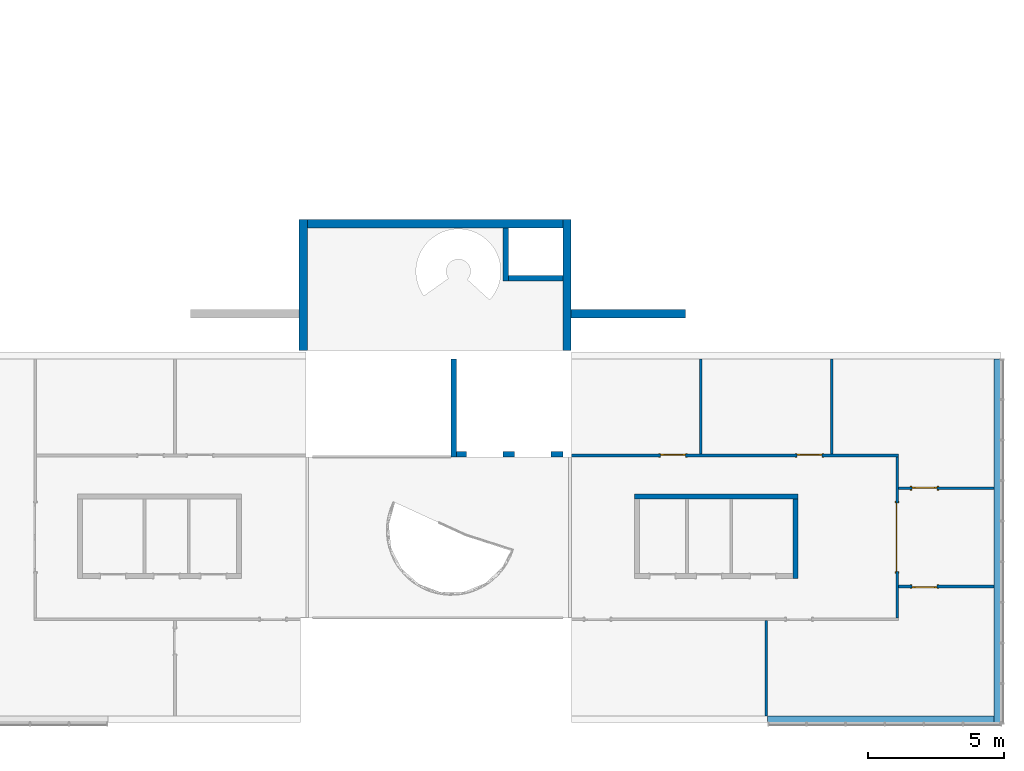
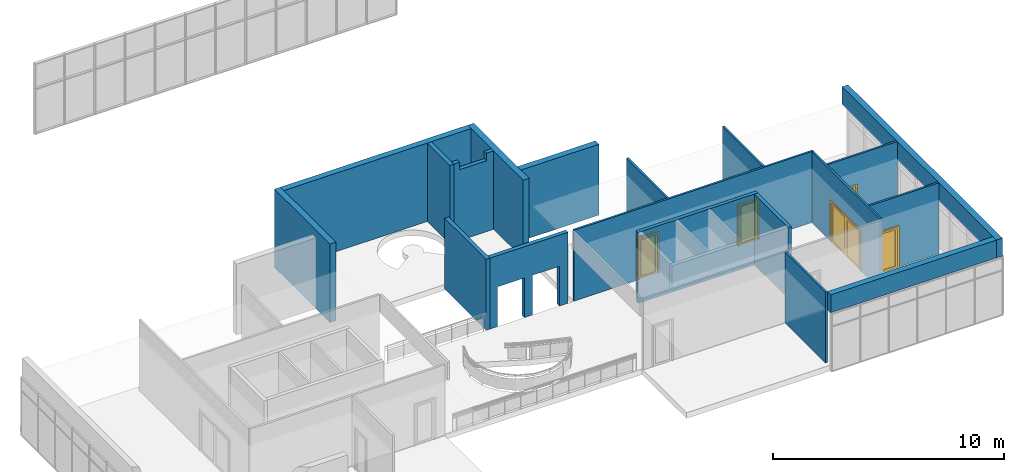
# One storey, part 9 of 11: 19 walls, 5 doors, 8 openings.
"""IFC2X3 building model written with IfcOpenShell, lengths in millimetres."""

from ifc_helpers import new_model, entity, si_unit, converted_unit, direction, frame, frame_2d, origin, origin_2d_with_axis, place, context, subcontext, project, spatial, polyline, rectangle, outline, extrude, source, transform, mapped, material, material_list, layer, layer_set, layer_usage, type_object, type_shapes, element, fill, save


model = new_model("IFC2X3")

# Units and contexts
model_context = context("Model", 3, precision=1e-06, world=origin(), true_north=direction((2.0, 6.12303176911189e-17, 1.0)))
context_of_model = context(None, 3, precision=1e-06, world=origin(), true_north=direction((2.0, 6.12303176911189e-17, 1.0)))
body_context = subcontext(model_context, "Body", "Model", "MODEL_VIEW")
ifc_project = project(units=[si_unit("LENGTHUNIT", "METRE", prefix="MILLI"), si_unit("AREAUNIT", "SQUARE_METRE", prefix="MILLI"), si_unit("VOLUMEUNIT", "CUBIC_METRE", prefix="MILLI"), converted_unit("PLANEANGLEUNIT", "DEGREE", entity("IfcRatioMeasure", 0.0174532925199433), si_unit("PLANEANGLEUNIT", "RADIAN"), dimensions=[0, 0, 0, 0, 0, 0, 0]), si_unit("TIMEUNIT", "SECOND")], contexts=[model_context, context_of_model])

# Site, building, storey
site_placement = place(None, origin())
site = spatial("IfcSite", under=ifc_project, at=site_placement, CompositionType="ELEMENT")
building_placement = place(site_placement, origin())
building = spatial("IfcBuilding", under=site, at=building_placement, CompositionType="ELEMENT")
storey_placement = place(building_placement, frame((0.0, 0.0, 3750.0)))
storey = spatial("IfcBuildingStorey", under=building, at=storey_placement, Name="02. 2 etg.", CompositionType="ELEMENT", Elevation=3750.00000000068)

# Wall, opening, door
ifc_material_1 = material(Name="Steel, Paint Finish, Ivory, Matte")
ifc_layer_1 = layer(ifc_material_1, 100.0)
ifc_layer_set_1 = layer_set([ifc_layer_1], Name="Basic Wall:_100mm")
ifc_layer_usage_1 = layer_usage(ifc_layer_set_1, "AXIS2", "POSITIVE", -50.0)
wall_1_placement = place(storey_placement, frame((37258.2357123495, -9550.0, 0.0), z_axis=(0.0, 0.0, 1.0), x_axis=(0.0, 1.0, 0.0)))
wall_1 = element("IfcWallStandardCase", 1, at=wall_1_placement, inside=storey, material=ifc_layer_usage_1, Name="Basic Wall:_100mm", ObjectType="Basic Wall:_100mm", context=body_context, shape_type="SweptSolid", body=[
    extrude(rectangle(XDim=5900.0, YDim=100.000000000003, at=frame_2d((2950.0, 0.0), x_axis=(-1.0, 0.0))), origin(), (0.0, 0.0, 1.0), 3750.0),
])
opening_1_placement = place(wall_1_placement, frame((1700.0, -50.0, 0.0)))
opening_1 = element("IfcOpeningElement", 2, at=opening_1_placement, cuts=wall_1, Name="M_Double-Glass 1:2500x2100:2500x2100:1", ObjectType="Opening", context=body_context, shape_type="SweptSolid", body=[
    extrude(rectangle(XDim=2500.0, YDim=2100.0, at=frame_2d((1050.0, 1250.0), x_axis=(0.0, 1.0))), frame((0.0, 0.0, 0.0), z_axis=(0.0, 1.0, 0.0), x_axis=(0.0, 0.0, 1.0)), (0.0, 0.0, 1.0), 100.0),
])
ifc_material_2 = material(Name="Metal - Stainless Steel,Polished")
ifc_material_3 = material(Name="Glass")
ifc_material_4 = material(Name="Steel, Chrome Plated")
ifc_material_list_1 = material_list([ifc_material_2, ifc_material_3, ifc_material_4])
door_style_1 = type_object("IfcDoorStyle", Name="2500x2100", ConstructionType="NOTDEFINED", OperationType="DOUBLE_DOOR_SINGLE_SWING", ParameterTakesPrecedence=False, Sizeable=False)
shared_shape_1 = source(origin(), body_context, "Body", "SweptSolid", [
    extrude(outline(polyline([(-1326.0, -1069.0), (-1250.0, -1069.0), (-1250.0, 1031.0), (1250.0, 1031.0), (1250.0, -1069.0), (1326.0, -1069.0), (1326.0, 1107.0), (-1326.0, 1107.0), (-1326.0, -1069.0)])), frame((1250.0, -25.0, 1069.0), z_axis=(0.0, 1.0, 0.0), x_axis=(-1.0, 0.0, 0.0)), (0.0, 0.0, 1.0), 25.0),
    extrude(outline(polyline([(-1250.0, -1031.0), (-1250.0, 1069.0), (-1326.0, 1069.0), (-1326.0, -1107.0), (1326.0, -1107.0), (1326.0, 1069.0), (1250.0, 1069.0), (1250.0, -1031.0), (-1250.0, -1031.0)])), frame((1250.0, 100.0, 1069.0), z_axis=(0.0, -1.0, 0.0), x_axis=(-1.0, 0.0, 0.0)), (0.0, 0.0, -1.0), 24.999999999997),
    extrude(rectangle(XDim=7.14374999999973, YDim=1046.8, at=frame_2d((0.0, -5.6843418860808e-14), x_axis=(1.0, 0.0))), frame((1875.0, 78.1718749999958, 102.0), z_axis=(0.0, 0.0, 1.0), x_axis=(0.0, 1.0, 0.0)), (0.0, 0.0, 1.0), 1896.0),
    extrude(rectangle(XDim=7.14374999999973, YDim=1046.8, at=frame_2d((0.0, -5.6843418860808e-14), x_axis=(1.0, 0.0))), frame((625.0, 78.1718749999958, 102.0), z_axis=(0.0, 0.0, 1.0), x_axis=(0.0, 1.0, 0.0)), (0.0, 0.0, 1.0), 1896.0),
    extrude(outline(polyline([(-1050.0, -1250.0), (1050.0, -1250.0), (1050.0, 1250.0), (-1050.0, 1250.0), (-1050.0, -1250.0)]), holes=[polyline([(-948.0, 101.600000000038), (-948.0, 1148.40000000004), (948.0, 1148.40000000004), (948.0, 101.600000000038), (-948.0, 101.600000000038)]), polyline([(-948.0, -1148.39999999996), (-948.0, -101.599999999961), (948.0, -101.599999999961), (948.0, -1148.39999999996), (-948.0, -1148.39999999996)])]), frame((1250.0, 49.0, 1050.0), z_axis=(0.0, 1.0, 0.0), x_axis=(0.0, 0.0, -1.0)), (0.0, 0.0, 1.0), 51.0),
])
type_shapes(door_style_1, [shared_shape_1])
door_1_placement = place(opening_1_placement, origin())
door_1 = element("IfcDoor", 3, at=door_1_placement, inside=storey, type_object=door_style_1, material=ifc_material_list_1, Name="M_Double-Glass 1:2500x2100:2500x2100", ObjectType="2500x2100", OverallHeight=2100.0, OverallWidth=2500.0, context=body_context, shape_type="MappedRepresentation", body=[
    mapped(shared_shape_1, transform((0.0, 0.0, 0.0), scale=1.0)),
])
fill(opening_1, door_1)

# Wall
ifc_layer_usage_2 = layer_usage(ifc_layer_set_1, "AXIS2", "POSITIVE", -50.0)
wall_2_placement = place(storey_placement, frame((32458.2357123495, -13140.0, 0.0), z_axis=(0.0, 0.0, 1.0), x_axis=(0.0, 1.0, 0.0)))
element("IfcWallStandardCase", 4, at=wall_2_placement, inside=storey, material=ifc_layer_usage_2, Name="Basic Wall:_100mm", ObjectType="Basic Wall:_100mm", context=body_context, shape_type="SweptSolid", body=[
    extrude(rectangle(XDim=3490.00000000005, YDim=100.000000000003, at=frame_2d((1745.00000000002, 0.0), x_axis=(-1.0, 0.0))), origin(), (0.0, 0.0, 1.0), 3750.0),
])

# Wall, openings, doors
ifc_layer_usage_3 = layer_usage(ifc_layer_set_1, "AXIS2", "POSITIVE", -50.0)
wall_3_placement = place(storey_placement, frame((25318.2357123494, -3600.0, 0.0)))
wall_3 = element("IfcWallStandardCase", 5, at=wall_3_placement, inside=storey, material=ifc_layer_usage_3, Name="Basic Wall:_100mm", ObjectType="Basic Wall:_100mm", context=body_context, shape_type="SweptSolid", body=[
    extrude(rectangle(XDim=11990.0, YDim=100.0, at=frame_2d((5995.00000000001, 1.27897692436818e-13), x_axis=(-1.0, 0.0))), origin(), (0.0, 0.0, 1.0), 3750.0),
])
opening_2_placement = place(wall_3_placement, frame((8275.0, -50.0, 0.0)))
opening_2 = element("IfcOpeningElement", 6, at=opening_2_placement, cuts=wall_3, Name="M_Single-Glass 1:0915 x 2134mm:0915 x 2134mm:1", ObjectType="Opening", context=body_context, shape_type="SweptSolid", body=[
    extrude(rectangle(XDim=914.999999999999, YDim=2134.0, at=frame_2d((1067.0, 457.5), x_axis=(0.0, 1.0))), frame((0.0, 0.0, 0.0), z_axis=(0.0, 1.0, 0.0), x_axis=(0.0, 0.0, 1.0)), (0.0, 0.0, 1.0), 100.0),
])
opening_3_placement = place(wall_3_placement, frame((3275.0, -50.0, 0.0)))
opening_3 = element("IfcOpeningElement", 7, at=opening_3_placement, cuts=wall_3, Name="M_Single-Glass 1:0915 x 2134mm:0915 x 2134mm:1", ObjectType="Opening", context=body_context, shape_type="SweptSolid", body=[
    extrude(rectangle(XDim=914.999999999999, YDim=2134.0, at=frame_2d((1067.0, 457.5), x_axis=(0.0, 1.0))), frame((0.0, 0.0, 0.0), z_axis=(0.0, 1.0, 0.0), x_axis=(0.0, 0.0, 1.0)), (0.0, 0.0, 1.0), 100.0),
])
ifc_material_5 = material(Name="Stainless Steel")
ifc_material_list_2 = material_list([ifc_material_5, ifc_material_3])
door_style_2 = type_object("IfcDoorStyle", Name="0915 x 2134mm", ConstructionType="NOTDEFINED", OperationType="SINGLE_SWING_RIGHT", ParameterTakesPrecedence=False, Sizeable=False)
shared_shape_2 = source(origin(), body_context, "Body", "SweptSolid", [
    extrude(outline(polyline([(-457.500000000003, -1048.0), (-457.500000000003, 1086.0), (-533.499999999999, 1086.0), (-533.499999999999, -1124.0), (533.500000000001, -1124.0), (533.500000000001, 1086.0), (457.500000000001, 1086.0), (457.500000000001, -1048.0), (-457.500000000003, -1048.0)])), frame((457.500000000001, -25.0, 1086.0), z_axis=(0.0, -1.0, 0.0), x_axis=(-1.0, 0.0, 0.0)), (0.0, 0.0, -1.0), 25.0),
    extrude(outline(polyline([(-457.500000000001, -1048.0), (-457.500000000001, 1086.0), (-533.499999999997, 1086.0), (-533.499999999997, -1124.0), (533.499999999999, -1124.0), (533.499999999999, 1086.0), (457.499999999999, 1086.0), (457.499999999999, -1048.0), (-457.500000000001, -1048.0)])), frame((457.499999999999, 100.0, 1086.0), z_axis=(0.0, -1.0, 0.0), x_axis=(-1.0, 0.0, 0.0)), (0.0, 0.0, -1.0), 25.0000000000156),
    extrude(rectangle(XDim=6.35, YDim=711.0, at=frame_2d((-4.21884749357559e-15, 0.0), x_axis=(1.0, 0.0))), frame((457.5, 74.6000000000039, 102.0), z_axis=(0.0, 0.0, 1.0), x_axis=(0.0, 1.0, 0.0)), (0.0, 0.0, 1.0), 1930.0),
    extrude(outline(polyline([(-1067.0, -457.499999999998), (1067.0, -457.499999999998), (1067.0, 457.499999999998), (-1067.0, 457.499999999998), (-1067.0, -457.499999999998)]), holes=[polyline([(-965.0, 355.499999999998), (965.0, 355.499999999998), (965.0, -355.500000000002), (-965.0, -355.500000000002), (-965.0, 355.499999999998)])]), frame((457.499999999998, 49.0, 1067.0), z_axis=(0.0, 1.0, 0.0), x_axis=(0.0, 0.0, -1.0)), (0.0, 0.0, 1.0), 51.0),
])
type_shapes(door_style_2, [shared_shape_2])
door_2_placement = place(opening_2_placement, origin())
door_2 = element("IfcDoor", 8, at=door_2_placement, inside=storey, type_object=door_style_2, material=ifc_material_list_2, Name="M_Single-Glass 1:0915 x 2134mm:0915 x 2134mm", ObjectType="0915 x 2134mm", OverallHeight=2134.0, OverallWidth=915.0, context=body_context, shape_type="MappedRepresentation", body=[
    mapped(shared_shape_2, transform((0.0, 0.0, 0.0), scale=1.0)),
])
fill(opening_2, door_2)
ifc_material_list_3 = material_list([ifc_material_5, ifc_material_3])
door_3_placement = place(opening_3_placement, origin())
door_3 = element("IfcDoor", 9, at=door_3_placement, inside=storey, type_object=door_style_2, material=ifc_material_list_3, Name="M_Single-Glass 1:0915 x 2134mm:0915 x 2134mm", ObjectType="0915 x 2134mm", OverallHeight=2134.0, OverallWidth=915.0, context=body_context, shape_type="MappedRepresentation", body=[
    mapped(shared_shape_2, transform((0.0, 0.0, 0.0), scale=1.0)),
])
fill(opening_3, door_3)

# Wall, opening, door
ifc_layer_usage_4 = layer_usage(ifc_layer_set_1, "AXIS2", "POSITIVE", -50.0)
wall_4_placement = place(storey_placement, frame((37308.2357123495, -4800.0, 0.0)))
wall_4 = element("IfcWallStandardCase", 10, at=wall_4_placement, inside=storey, material=ifc_layer_usage_4, Name="Basic Wall:_100mm", ObjectType="Basic Wall:_100mm", context=body_context, shape_type="SweptSolid", body=[
    extrude(rectangle(XDim=3490.00000000001, YDim=100.0, at=frame_2d((1745.0, 0.0), x_axis=(-1.0, 0.0))), origin(), (0.0, 0.0, 1.0), 3750.0),
])
opening_4_placement = place(wall_4_placement, frame((500.0, -50.0, 0.0)))
opening_4 = element("IfcOpeningElement", 11, at=opening_4_placement, cuts=wall_4, Name="M_Single-Glass 1:0915 x 2134mm:0915 x 2134mm:1", ObjectType="Opening", context=body_context, shape_type="SweptSolid", body=[
    extrude(rectangle(XDim=914.999999999999, YDim=2134.0, at=frame_2d((1067.0, 457.5), x_axis=(0.0, -1.0))), frame((0.0, 0.0, 0.0), z_axis=(0.0, 1.0, 0.0), x_axis=(0.0, 0.0, 1.0)), (0.0, 0.0, 1.0), 100.0),
])
ifc_material_list_4 = material_list([ifc_material_5, ifc_material_3])
door_style_3 = type_object("IfcDoorStyle", Name="0915 x 2134mm", ConstructionType="NOTDEFINED", OperationType="SINGLE_SWING_LEFT", ParameterTakesPrecedence=False, Sizeable=False)
shared_shape_3 = source(origin(), body_context, "Body", "SweptSolid", [
    extrude(outline(polyline([(-457.500000000003, -1048.0), (-457.500000000003, 1086.0), (-533.499999999999, 1086.0), (-533.499999999999, -1124.0), (533.500000000001, -1124.0), (533.500000000001, 1086.0), (457.500000000001, 1086.0), (457.500000000001, -1048.0), (-457.500000000003, -1048.0)])), frame((457.499999999999, 0.0, 1086.0), z_axis=(0.0, 1.0, 0.0), x_axis=(1.0, 0.0, 0.0)), (0.0, 0.0, -1.0), 25.0),
    extrude(outline(polyline([(-457.500000000001, -1048.0), (-457.500000000001, 1086.0), (-533.499999999997, 1086.0), (-533.499999999997, -1124.0), (533.499999999999, -1124.0), (533.499999999999, 1086.0), (457.499999999999, 1086.0), (457.499999999999, -1048.0), (-457.500000000001, -1048.0)])), frame((457.500000000001, 125.0, 1086.0), z_axis=(0.0, 1.0, 0.0), x_axis=(1.0, 0.0, 0.0)), (0.0, 0.0, -1.0), 25.0000000000156),
    extrude(rectangle(XDim=711.0, YDim=6.35, at=origin_2d_with_axis()), frame((457.5, 74.6000000000257, 102.0)), (0.0, 0.0, 1.0), 1930.0),
    extrude(outline(polyline([(-1067.0, -457.499999999998), (1067.0, -457.499999999998), (1067.0, 457.499999999998), (-1067.0, 457.499999999998), (-1067.0, -457.499999999998)]), holes=[polyline([(-965.0, 355.499999999998), (965.0, 355.499999999998), (965.0, -355.500000000002), (-965.0, -355.500000000002), (-965.0, 355.499999999998)])]), frame((457.500000000002, 100.0, 1067.0), z_axis=(0.0, -1.0, 0.0), x_axis=(0.0, 0.0, -1.0)), (0.0, 0.0, 1.0), 51.0),
])
type_shapes(door_style_3, [shared_shape_3])
door_4_placement = place(opening_4_placement, origin())
door_4 = element("IfcDoor", 12, at=door_4_placement, inside=storey, type_object=door_style_3, material=ifc_material_list_4, Name="M_Single-Glass 1:0915 x 2134mm:0915 x 2134mm", ObjectType="0915 x 2134mm", OverallHeight=2134.0, OverallWidth=915.0, context=body_context, shape_type="MappedRepresentation", body=[
    mapped(shared_shape_3, transform((0.0, 0.0, 0.0), scale=1.0)),
])
fill(opening_4, door_4)

ifc_layer_usage_5 = layer_usage(ifc_layer_set_1, "AXIS2", "POSITIVE", -50.0)
wall_5_placement = place(storey_placement, frame((37308.2357123495, -8400.0, 0.0)))
wall_5 = element("IfcWallStandardCase", 13, at=wall_5_placement, inside=storey, material=ifc_layer_usage_5, Name="Basic Wall:_100mm", ObjectType="Basic Wall:_100mm", context=body_context, shape_type="SweptSolid", body=[
    extrude(rectangle(XDim=3490.00000000002, YDim=99.9999999999989, at=frame_2d((1745.00000000001, 0.0), x_axis=(-1.0, 0.0))), origin(), (0.0, 0.0, 1.0), 3750.0),
])
opening_5_placement = place(wall_5_placement, frame((1415.0, 50.0, 0.0)))
opening_5 = element("IfcOpeningElement", 14, at=opening_5_placement, cuts=wall_5, Name="M_Single-Glass 1:0915 x 2134mm:0915 x 2134mm:1", ObjectType="Opening", context=body_context, shape_type="SweptSolid", body=[
    extrude(rectangle(XDim=914.999999999999, YDim=2134.0, at=frame_2d((1067.0, 457.5), x_axis=(0.0, 1.0))), frame((0.0, 0.0, 0.0), z_axis=(0.0, -1.0, 0.0), x_axis=(0.0, 0.0, 1.0)), (0.0, 0.0, 1.0), 100.0),
])
ifc_material_list_5 = material_list([ifc_material_5, ifc_material_3])
door_5_placement = place(opening_5_placement, frame((0.0, 0.0, 0.0), z_axis=(0.0, 0.0, 1.0), x_axis=(-1.0, 0.0, 0.0)))
door_5 = element("IfcDoor", 15, at=door_5_placement, inside=storey, type_object=door_style_2, material=ifc_material_list_5, Name="M_Single-Glass 1:0915 x 2134mm:0915 x 2134mm", ObjectType="0915 x 2134mm", OverallHeight=2134.0, OverallWidth=915.0, context=body_context, shape_type="MappedRepresentation", body=[
    mapped(shared_shape_2, transform((0.0, 0.0, 0.0), scale=1.0)),
])
fill(opening_5, door_5)

# Walls
ifc_layer_usage_6 = layer_usage(ifc_layer_set_1, "AXIS2", "POSITIVE", -50.0)
wall_6_placement = place(storey_placement, frame((34858.2357123495, -3550.0, 0.0), z_axis=(0.0, 0.0, 1.0), x_axis=(0.0, 1.0, 0.0)))
element("IfcWallStandardCase", 16, at=wall_6_placement, inside=storey, material=ifc_layer_usage_6, Name="Basic Wall:_100mm", ObjectType="Basic Wall:_100mm", context=body_context, shape_type="SweptSolid", body=[
    extrude(rectangle(XDim=3490.00000000001, YDim=100.000000000003, at=frame_2d((1745.00000000001, 0.0), x_axis=(-1.0, 0.0))), origin(), (0.0, 0.0, 1.0), 3750.0),
])
ifc_layer_usage_7 = layer_usage(ifc_layer_set_1, "AXIS2", "POSITIVE", -50.0)
wall_7_placement = place(storey_placement, frame((30058.2357123495, -3550.0, 0.0), z_axis=(0.0, 0.0, 1.0), x_axis=(0.0, 1.0, 0.0)))
element("IfcWallStandardCase", 17, at=wall_7_placement, inside=storey, material=ifc_layer_usage_7, Name="Basic Wall:_100mm", ObjectType="Basic Wall:_100mm", context=body_context, shape_type="SweptSolid", body=[
    extrude(rectangle(XDim=3490.00000000001, YDim=100.000000000003, at=frame_2d((1745.00000000001, 0.0), x_axis=(-1.0, 0.0))), origin(), (0.0, 0.0, 1.0), 3750.0),
])
ifc_layer_2 = layer(ifc_material_1, 180.0)
ifc_layer_set_2 = layer_set([ifc_layer_2], Name="Basic Wall:_180mm")
ifc_layer_usage_8 = layer_usage(ifc_layer_set_2, "AXIS2", "POSITIVE", -90.0)
wall_8_placement = place(storey_placement, frame((33629.1178561747, -5096.65631369453, 0.0), z_axis=(0.0, 0.0, 1.0), x_axis=(-1.0, 0.0, 0.0)))
element("IfcWallStandardCase", 18, at=wall_8_placement, inside=storey, material=ifc_layer_usage_8, Name="Basic Wall:_180mm", ObjectType="Basic Wall:_180mm", context=body_context, shape_type="SweptSolid", body=[
    extrude(rectangle(XDim=5999.99999999999, YDim=180.0, at=frame_2d((3000.0, 0.0), x_axis=(-1.0, 0.0))), origin(), (0.0, 0.0, 1.0), 3750.0),
])
ifc_layer_usage_9 = layer_usage(ifc_layer_set_2, "AXIS2", "POSITIVE", -90.0)
wall_9_placement = place(storey_placement, frame((33539.1178561747, -8106.65631369453, 0.0), z_axis=(0.0, 0.0, 1.0), x_axis=(0.0, 1.0, 0.0)))
element("IfcWallStandardCase", 19, at=wall_9_placement, inside=storey, material=ifc_layer_usage_9, Name="Basic Wall:_180mm", ObjectType="Basic Wall:_180mm", context=body_context, shape_type="SweptSolid", body=[
    extrude(rectangle(XDim=2920.0, YDim=180.000000000002, at=frame_2d((1460.0, 0.0), x_axis=(-1.0, 0.0))), origin(), (0.0, 0.0, 1.0), 3750.0),
])
ifc_material_6 = material(Name="Default Wall")
ifc_layer_3 = layer(ifc_material_6, 200.0)
ifc_layer_set_3 = layer_set([ifc_layer_3], Name="Basic Wall:Generic - 200mm")
ifc_layer_usage_10 = layer_usage(ifc_layer_set_3, "AXIS2", "NEGATIVE", 100.0)
wall_10_placement = place(storey_placement, frame((21013.8966271322, -60.0, 0.0), z_axis=(0.0, 0.0, 1.0), x_axis=(0.0, -1.0, 0.0)))
element("IfcWallStandardCase", 20, at=wall_10_placement, inside=storey, material=ifc_layer_usage_10, Name="Basic Wall:Generic - 200mm", ObjectType="Basic Wall:Generic - 200mm:398", context=body_context, shape_type="SweptSolid", body=[
    extrude(rectangle(XDim=3590.00000000001, YDim=199.999999999998, at=frame_2d((1795.0, 1.35003119794419e-13), x_axis=(-1.0, 0.0))), origin(), (0.0, 0.0, 1.0), 3750.0),
])

# Wall, openings
ifc_layer_usage_11 = layer_usage(ifc_layer_set_3, "AXIS2", "NEGATIVE", 100.0)
wall_11_placement = place(storey_placement, frame((21113.8966271322, -3550.0, 0.0)))
wall_11 = element("IfcWallStandardCase", 21, at=wall_11_placement, inside=storey, material=ifc_layer_usage_11, Name="Basic Wall:Generic - 200mm", ObjectType="Basic Wall:Generic - 200mm:398", context=body_context, shape_type="SweptSolid", body=[
    extrude(rectangle(XDim=3904.33908521726, YDim=200.0, at=frame_2d((1952.16954260863, -3.5527136788005e-14), x_axis=(-1.0, 0.0))), origin(), (0.0, 0.0, 1.0), 3750.0),
])
opening_6_placement = place(wall_11_placement, origin())
element("IfcOpeningElement", 22, at=opening_6_placement, cuts=wall_11, ObjectType="Opening", context=body_context, shape_type="SweptSolid", body=[
    extrude(rectangle(XDim=2100.0, YDim=1340.00356586779, at=origin_2d_with_axis()), frame((2793.33730752032, -1624.0, 1050.0), z_axis=(0.0, 1.0, 0.0), x_axis=(0.0, 0.0, -1.0)), (0.0, 0.0, 1.0), 3048.0),
])
opening_7_placement = place(wall_11_placement, origin())
element("IfcOpeningElement", 23, at=opening_7_placement, cuts=wall_11, ObjectType="Opening", context=body_context, shape_type="SweptSolid", body=[
    extrude(rectangle(XDim=2100.0, YDim=1340.00356586779, at=origin_2d_with_axis()), frame((1038.99822231269, -1624.0, 1050.0), z_axis=(0.0, 1.0, 0.0), x_axis=(0.0, 0.0, -1.0)), (0.0, 0.0, 1.0), 3048.0),
])

# Walls
ifc_material_7 = material(Name="Brick, Engineering, Soldier Course")
ifc_layer_4 = layer(ifc_material_7, 300.0)
ifc_layer_set_4 = layer_set([ifc_layer_4], Name="Basic Wall:Generic - 300mm")
ifc_layer_usage_12 = layer_usage(ifc_layer_set_4, "AXIS2", "NEGATIVE", 150.0)
wall_12_placement = place(storey_placement, frame((29499.1178561747, 1590.0, 0.0), z_axis=(0.0, 0.0, 1.0), x_axis=(-1.0, 0.0, 0.0)))
element("IfcWallStandardCase", 24, at=wall_12_placement, inside=storey, material=ifc_layer_usage_12, Name="Basic Wall:Generic - 300mm", ObjectType="Basic Wall:Generic - 300mm:6291", context=body_context, shape_type="SweptSolid", body=[
    extrude(rectangle(XDim=4185.22122904255, YDim=300.0, at=frame_2d((2092.61061452127, 0.0), x_axis=(-1.0, 0.0))), origin(), (0.0, 0.0, 1.0), 3750.0),
])
ifc_layer_usage_13 = layer_usage(ifc_layer_set_4, "AXIS2", "NEGATIVE", 150.0)
wall_13_placement = place(storey_placement, frame((15494.0, 240.0, 0.0), z_axis=(0.0, 0.0, 1.0), x_axis=(0.0, 1.0, 0.0)))
element("IfcWallStandardCase", 25, at=wall_13_placement, inside=storey, material=ifc_layer_usage_13, Name="Basic Wall:Generic - 300mm", ObjectType="Basic Wall:Generic - 300mm:6291", context=body_context, shape_type="SweptSolid", body=[
    extrude(rectangle(XDim=4800.0, YDim=300.000000000001, at=frame_2d((2400.0, 5.6843418860808e-14), x_axis=(-1.0, 0.0))), origin(), (0.0, 0.0, 1.0), 4149.99999999993),
])
ifc_layer_usage_14 = layer_usage(ifc_layer_set_4, "AXIS2", "NEGATIVE", 150.0)
wall_14_placement = place(storey_placement, frame((25163.8966271322, 5040.0, 0.0), z_axis=(0.0, 0.0, 1.0), x_axis=(0.0, -1.0, 0.0)))
element("IfcWallStandardCase", 26, at=wall_14_placement, inside=storey, material=ifc_layer_usage_14, Name="Basic Wall:Generic - 300mm", ObjectType="Basic Wall:Generic - 300mm:6291", context=body_context, shape_type="SweptSolid", body=[
    extrude(rectangle(XDim=4799.99999999996, YDim=300.000000000001, at=frame_2d((2399.99999999998, 8.38440428196918e-13), x_axis=(-1.0, 0.0))), origin(), (0.0, 0.0, 1.0), 4149.99999999993),
])
ifc_layer_usage_15 = layer_usage(ifc_layer_set_4, "AXIS2", "NEGATIVE", 150.0)
wall_15_placement = place(storey_placement, frame((15644.0, 4890.0, 0.0)))
element("IfcWallStandardCase", 27, at=wall_15_placement, inside=storey, material=ifc_layer_usage_15, Name="Basic Wall:Generic - 300mm", ObjectType="Basic Wall:Generic - 300mm:6291", context=body_context, shape_type="SweptSolid", body=[
    extrude(rectangle(XDim=9369.89662713216, YDim=300.0, at=frame_2d((4684.94831356608, -4.9737991503207e-13), x_axis=(-1.0, 0.0))), origin(), (0.0, 0.0, 1.0), 4149.99999999993),
])
ifc_layer_usage_16 = layer_usage(ifc_layer_set_3, "AXIS2", "NEGATIVE", 100.0)
wall_16_placement = place(storey_placement, frame((22913.8966271322, 4740.0, 0.0), z_axis=(0.0, 0.0, 1.0), x_axis=(0.0, -1.0, 0.0)))
element("IfcWallStandardCase", 28, at=wall_16_placement, inside=storey, material=ifc_layer_usage_16, Name="Basic Wall:Generic - 200mm", ObjectType="Basic Wall:Generic - 200mm:398", context=body_context, shape_type="SweptSolid", body=[
    extrude(rectangle(XDim=1950.0, YDim=199.999999999998, at=frame_2d((975.0, -6.82121026329696e-13), x_axis=(-1.0, 0.0))), origin(), (0.0, 0.0, 1.0), 4149.99999999993),
])

# Wall, opening
ifc_layer_usage_17 = layer_usage(ifc_layer_set_3, "AXIS2", "NEGATIVE", 100.0)
wall_17_placement = place(storey_placement, frame((23013.8966271322, 2890.0, 0.0)))
wall_17 = element("IfcWallStandardCase", 29, at=wall_17_placement, inside=storey, material=ifc_layer_usage_17, Name="Basic Wall:Generic - 200mm", ObjectType="Basic Wall:Generic - 200mm:398", context=body_context, shape_type="SweptSolid", body=[
    extrude(rectangle(XDim=2000.00000000001, YDim=200.0, at=frame_2d((1000.0, -4.9737991503207e-14), x_axis=(-1.0, 0.0))), origin(), (0.0, 0.0, 1.0), 4149.99999999993),
])
opening_8_placement = place(wall_17_placement, origin())
element("IfcOpeningElement", 30, at=opening_8_placement, cuts=wall_17, ObjectType="Opening", context=body_context, shape_type="SweptSolid", body=[
    extrude(rectangle(XDim=2100.0, YDim=1340.00356586779, at=origin_2d_with_axis()), frame((963.998222307887, -1624.0, 4800.0), z_axis=(0.0, 1.0, 0.0), x_axis=(0.0, 0.0, -1.0)), (0.0, 0.0, 1.0), 3048.0),
])

# Walls
ifc_layer_usage_18 = layer_usage(ifc_layer_set_4, "AXIS2", "POSITIVE", -150.0)
wall_18_placement = place(storey_placement, frame((40948.2357123495, -60.0, 2800.0), z_axis=(0.0, 0.0, 1.0), x_axis=(0.0, -1.0, 0.0)))
element("IfcWallStandardCase", 31, at=wall_18_placement, inside=storey, material=ifc_layer_usage_18, Name="Basic Wall:Generic - 300mm", ObjectType="Basic Wall:Generic - 300mm:6291", context=body_context, shape_type="SweptSolid", body=[
    extrude(rectangle(XDim=13380.0000000001, YDim=300.000000000001, at=frame_2d((6690.00000000003, -1.09423581307055e-12), x_axis=(-1.0, 0.0))), origin(), (0.0, 0.0, 1.0), 949.999999999925),
])
ifc_layer_usage_19 = layer_usage(ifc_layer_set_4, "AXIS2", "NEGATIVE", 150.0)
wall_19_placement = place(storey_placement, frame((32508.2357123495, -13290.0, 2800.0)))
element("IfcWallStandardCase", 32, at=wall_19_placement, inside=storey, material=ifc_layer_usage_19, Name="Basic Wall:Generic - 300mm", ObjectType="Basic Wall:Generic - 300mm:6291", context=body_context, shape_type="SweptSolid", body=[
    extrude(rectangle(XDim=8290.00000000003, YDim=300.000000000001, at=frame_2d((4145.00000000001, 4.68958205601666e-13), x_axis=(-1.0, 0.0))), origin(), (0.0, 0.0, 1.0), 949.999999999925),
])

save(model, "model.ifc")
